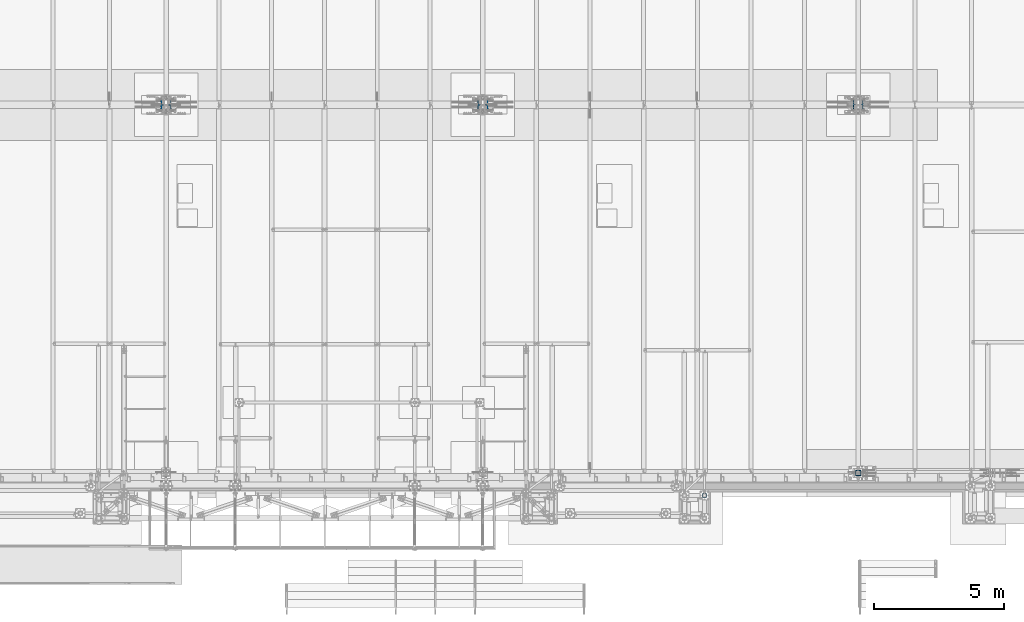
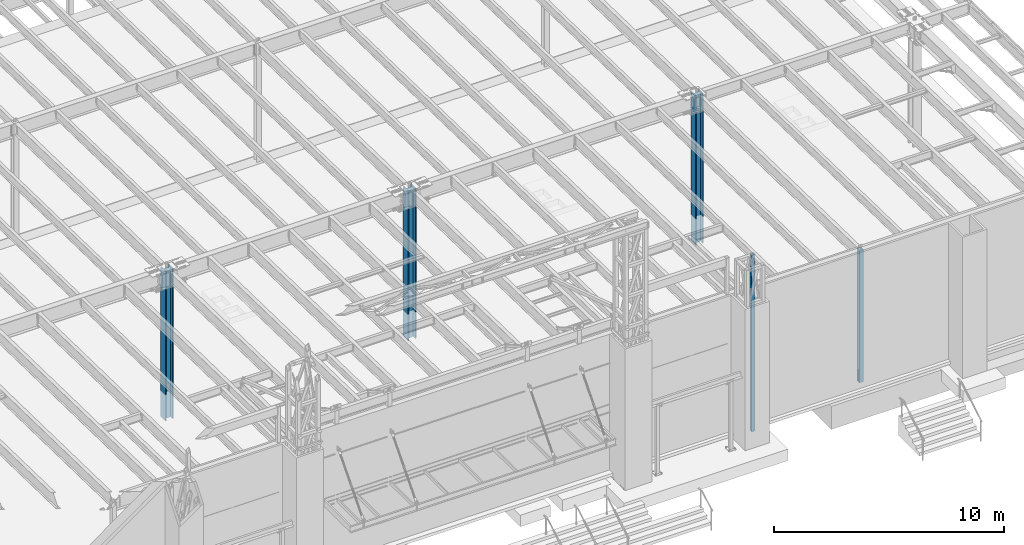
# One storey, part 897 of 1763: 5 columns, 5 elements without a shape of their own.
"""IFC2X3 building model written with IfcOpenShell, lengths in millimetres."""

from ifc_helpers import new_model, si_unit, frame, origin_with_axes, place, context, subcontext, project, spatial, faceted_brep, material, type_object, element, aggregate, save


model = new_model("IFC2X3")

# Units and contexts
model_context = context("Model", 3, precision=1e-05, world=origin_with_axes())
body_context = subcontext(model_context, "Body", "Model", "MODEL_VIEW")
ifc_project = project(units=[si_unit("LENGTHUNIT", "METRE", prefix="MILLI"), si_unit("AREAUNIT", "SQUARE_METRE"), si_unit("VOLUMEUNIT", "CUBIC_METRE"), si_unit("MASSUNIT", "GRAM", prefix="KILO"), si_unit("TIMEUNIT", "SECOND"), si_unit("PLANEANGLEUNIT", "RADIAN"), si_unit("SOLIDANGLEUNIT", "STERADIAN"), si_unit("THERMODYNAMICTEMPERATUREUNIT", "DEGREE_CELSIUS"), si_unit("LUMINOUSINTENSITYUNIT", "LUMEN")], contexts=[model_context])

# Site, building, storey
site_placement = place(None, origin_with_axes())
site = spatial("IfcSite", under=ifc_project, at=site_placement, CompositionType="ELEMENT")
building_placement = place(site_placement, origin_with_axes())
building = spatial("IfcBuilding", under=site, at=building_placement, Name="Undefined", CompositionType="ELEMENT")
storey_placement = place(building_placement, origin_with_axes())
storey = spatial("IfcBuildingStorey", under=building, at=storey_placement, Name="Undefined", CompositionType="ELEMENT", Elevation=0.0)

# Assembly, column
assembly_1_placement = place(storey_placement, origin_with_axes())
assembly_1 = element("IfcElementAssembly", 1, at=assembly_1_placement, inside=storey, Name="FRAME", AssemblyPlace="NOTDEFINED", PredefinedType="RIGID_FRAME")
ifc_material_1 = material()
column_type_1 = type_object("IfcColumnType", Name="HSS6X6X5/8", PredefinedType="NOTDEFINED")
column_1_placement = place(assembly_1_placement, frame((-40868.0383006056, -14579.5306029674, 5029.2), z_axis=(0.0, 1.0, 0.0), x_axis=(0.0, 0.0, 1.0)))
column_1 = element("IfcColumn", 2, at=column_1_placement, type_object=column_type_1, material=ifc_material_1, Name="COLUMN", ObjectType="HSS6X6X5/8", context=body_context, shape_type="Brep", body=[
    faceted_brep([(63.4999999999973, 60.3249999999971, -60.3250000000007), (63.4999999999973, -60.3249999999971, -60.3250000000007), (9429.74999873329, -60.3250000149637, -60.3250000000007), (9429.75000126672, 60.3249999850377, -60.3250000000007), (63.4999999999973, -60.3249999999971, 60.3250000000007), (9429.74999873329, -60.3250000149637, 60.3250000000007), (63.4999999999973, 60.3249999999971, 60.3250000000007), (9429.75000126672, 60.3249999850377, 60.3250000000007), (63.4999999999973, 76.1999999999971, -76.2000000000007), (63.4999999999973, 76.1999999999971, 76.2000000000007), (9429.75000000001, 76.1999999999971, 76.2000000000007), (9429.75000000001, 76.1999999999971, -76.2000000000007), (63.4999999999973, -76.1999999999971, 76.2000000000007), (9429.75000000001, -76.1999999999971, 76.2000000000007), (63.4999999999973, -76.1999999999971, -76.2000000000007), (9429.75000000001, -76.1999999999971, -76.2000000000007)], [[[0, 1, 2, 3]], [[1, 4, 5, 2]], [[4, 6, 7, 5]], [[6, 0, 3, 7]], [[8, 9, 10, 11]], [[9, 12, 13, 10]], [[12, 14, 15, 13]], [[14, 8, 11, 15]], [[13, 15, 11, 10], [5, 7, 3, 2]], [[14, 12, 9, 8], [6, 4, 1, 0]]]),
])
aggregate(assembly_1, [column_1])

assembly_2_placement = place(storey_placement, origin_with_axes())
assembly_2 = element("IfcElementAssembly", 3, at=assembly_2_placement, inside=storey, Name="COLUMN", AssemblyPlace="NOTDEFINED", PredefinedType="RIGID_FRAME")
column_type_2 = type_object("IfcColumnType", Name="HSS8X8X1/2", PredefinedType="NOTDEFINED")
column_2_placement = place(assembly_2_placement, frame((-34949.8372736984, -13716.0, 5029.2), z_axis=(0.0, 1.0, 0.0), x_axis=(0.0, 0.0, 1.0)))
column_2 = element("IfcColumn", 4, at=column_2_placement, type_object=column_type_2, material=ifc_material_1, Name="COLUMN", ObjectType="HSS8X8X1/2", context=body_context, shape_type="Brep", body=[
    faceted_brep([(7150.10000000001, 88.9000000000015, 6.35018100146408), (7137.40000000001, 101.599999999999, 6.35018100146408), (6491.28751239777, 101.599999999999, 6.35018100146408), (6491.28751239777, 88.9000000000015, 6.35018100146408), (6487.03494268262, 101.599999999999, 7.19606971095163), (6487.03494268262, 88.9000000000015, 7.19606971095163), (6483.42978815696, 101.599999999999, 9.60495695139434), (6483.42978815696, 88.9000000000015, 9.60495695139434), (6481.02090091652, 101.599999999999, 13.2101114770503), (6481.02090091652, 88.9000000000015, 13.2101114770503), (6480.17501220703, 101.599999999999, 17.4626811921989), (6480.17501220703, 88.9000000000015, 17.4626811921989), (6481.02090091652, 101.599999999999, 21.7152509073476), (6481.02090091652, 88.9000000000015, 21.7152509073476), (6483.42978815696, 101.599999999999, 25.3204054330035), (6483.42978815696, 88.9000000000015, 25.3204054330035), (6487.03494268262, 101.599999999999, 27.7292926734463), (6487.03494268262, 88.9000000000015, 27.7292926734463), (6491.28751239777, 101.599999999999, 28.5751813829338), (6491.28751239777, 88.9000000000015, 28.5751813829338), (7150.10000000001, 88.9000000000015, 28.5751813829338), (7137.40000000001, 101.599999999999, 28.5751813829338), (101.599999999999, 88.9000000000015, 14.2875007629391), (101.599999999999, 101.599999999999, 14.2875007629391), (763.464319038182, 101.599999999999, 14.2875007629391), (763.464319038182, 88.9000000000015, 14.2875007629391), (768.324398556228, 101.599999999999, 13.3207708403515), (768.324398556228, 88.9000000000015, 13.3207708403515), (772.444575024381, 101.599999999999, 10.567756939874), (772.444575024381, 88.9000000000015, 10.567756939874), (775.19758892486, 101.599999999999, 6.44758047172036), (775.19758892486, 88.9000000000015, 6.44758047172036), (776.164318847447, 101.599999999999, 1.58750095367395), (776.164318847447, 88.9000000000015, 1.58750095367395), (776.164318847447, 101.599999999999, -1.58750019073523), (776.164318847447, 88.9000000000015, -1.58750019073523), (775.19758892486, 101.599999999999, -6.44757970878163), (775.19758892486, 88.9000000000015, -6.44757970878163), (772.444575024381, 101.599999999999, -10.5677561769353), (772.444575024381, 88.9000000000015, -10.5677561769353), (768.324398556228, 101.599999999999, -13.3207700774128), (768.324398556228, 88.9000000000015, -13.3207700774128), (763.464319038182, 101.599999999999, -14.2875000000004), (763.464319038182, 88.9000000000015, -14.2875000000004), (101.599999999999, 101.599999999999, -14.2875000000004), (101.599999999999, 88.9000000000015, -14.2875000000004), (6588.91045414009, -15.8749990520446, 88.8999999999996), (6588.91045414009, -15.8749990520446, 101.6), (7137.40000000001, -15.8749990520446, 101.6), (7150.10000000001, -15.8749990520446, 88.8999999999996), (6586.48041438107, -15.3916340907526, 88.8999999999996), (6586.48041438107, -15.3916340907526, 101.6), (6584.42032614699, -14.015127140512, 88.8999999999996), (6584.42032614699, -14.015127140512, 101.6), (6583.04381919675, -11.9550389064316, 88.8999999999996), (6583.04381919675, -11.9550389064316, 101.6), (6582.56045423546, -9.52499914741202, 88.8999999999996), (6582.56045423546, -9.52499914741202, 101.6), (6583.04381919675, -7.09495938839245, 88.8999999999996), (6583.04381919675, -7.09495938839245, 101.6), (6584.42032614699, -5.03487115431199, 88.8999999999996), (6584.42032614699, -5.03487115431199, 101.6), (6586.48041438107, -3.6583642040714, 88.8999999999996), (6586.48041438107, -3.6583642040714, 101.6), (6588.91045414009, -3.17499924277945, 88.8999999999996), (6588.91045414009, -3.17499924277945, 101.6), (7150.10000000001, -3.17499924277945, 88.8999999999996), (7137.40000000001, -3.17499924277945, 101.6), (7137.40000000001, 101.599999999999, 101.6), (101.599999999999, 101.599999999999, 101.6), (101.599999999999, -101.599999999999, 101.6), (7137.40000000001, -101.599999999999, 101.6), (101.599999999999, 88.9000000000015, -88.8999999999996), (101.599999999999, -88.9000000000015, -88.8999999999996), (7150.10000000001, -88.9000000000015, -88.8999999999996), (7150.10000000001, 88.9000000000015, -88.8999999999996), (101.599999999999, -101.599999999999, -101.6), (101.599999999999, 101.599999999999, -101.6), (7137.40000000001, 101.599999999999, -101.6), (7137.40000000001, -101.599999999999, -101.6), (7150.10000000001, -88.9000000000015, 6.35018100146408), (7137.40000000001, -101.599999999999, 6.35018100146408), (6491.28750019074, -88.9000000000015, 6.35018100146408), (6491.28750019074, -101.599999999999, 6.35018100146408), (6487.03493047559, -88.9000000000015, 7.19606971095163), (6487.03493047559, -101.599999999999, 7.19606971095163), (6483.42977594993, -88.9000000000015, 9.60495695139434), (6483.42977594993, -101.599999999999, 9.60495695139434), (6481.02088870949, -88.9000000000015, 13.2101114770503), (6481.02088870949, -101.599999999999, 13.2101114770503), (6480.175, -88.9000000000015, 17.4626811921989), (6480.175, -101.599999999999, 17.4626811921989), (6481.02088870949, -88.9000000000015, 21.7152509073476), (6481.02088870949, -101.599999999999, 21.7152509073476), (6483.42977594993, -88.9000000000015, 25.3204054330035), (6483.42977594993, -101.599999999999, 25.3204054330035), (6487.03493047559, -88.9000000000015, 27.7292926734463), (6487.03493047559, -101.599999999999, 27.7292926734463), (101.599999999999, -101.599999999999, 14.2875007629391), (763.464319038182, -101.599999999999, 14.2875007629391), (768.324398556228, -101.599999999999, 13.3207708403515), (772.444575024381, -101.599999999999, 10.567756939874), (775.19758892486, -101.599999999999, 6.44758047172036), (776.164318847447, -101.599999999999, 1.58750095367395), (776.164318847447, -101.599999999999, -1.58750019073523), (775.19758892486, -101.599999999999, -6.44757970878163), (772.444575024381, -101.599999999999, -10.5677561769353), (768.324398556228, -101.599999999999, -13.3207700774128), (763.464319038182, -101.599999999999, -14.2875000000004), (101.599999999999, -101.599999999999, -14.2875000000004), (6491.28750019074, -101.599999999999, 28.5751813829338), (7137.40000000001, -101.599999999999, 28.5751813829338), (101.599999999999, -88.9000000000015, -14.2875000000004), (763.464319038182, -88.9000000000015, -14.2875000000004), (768.324398556228, -88.9000000000015, -13.3207700774128), (772.444575024381, -88.9000000000015, -10.5677561769353), (775.19758892486, -88.9000000000015, -6.44757970878163), (776.164318847447, -88.9000000000015, -1.58750019073523), (776.164318847447, -88.9000000000015, 1.58750095367395), (775.19758892486, -88.9000000000015, 6.44758047172036), (772.444575024381, -88.9000000000015, 10.567756939874), (768.324398556228, -88.9000000000015, 13.3207708403515), (763.464319038182, -88.9000000000015, 14.2875007629391), (101.599999999999, -88.9000000000015, 14.2875007629391), (101.599999999999, 88.9000000000015, 88.8999999999996), (101.599999999999, -88.9000000000015, 88.8999999999996), (7150.10000000001, -88.9000000000015, 88.8999999999996), (7150.10000000001, -88.9000000000015, 28.5751813829338), (6491.28750019074, -88.9000000000015, 28.5751813829338), (7150.10000000001, 88.9000000000015, 88.8999999999996)], [[[0, 1, 2, 3]], [[3, 2, 4, 5]], [[5, 4, 6, 7]], [[7, 6, 8, 9]], [[9, 8, 10, 11]], [[11, 10, 12, 13]], [[13, 12, 14, 15]], [[15, 14, 16, 17]], [[17, 16, 18, 19]], [[20, 19, 18, 21]], [[22, 23, 24, 25]], [[25, 24, 26, 27]], [[27, 26, 28, 29]], [[29, 28, 30, 31]], [[31, 30, 32, 33]], [[33, 32, 34, 35]], [[35, 34, 36, 37]], [[37, 36, 38, 39]], [[39, 38, 40, 41]], [[41, 40, 42, 43]], [[43, 42, 44, 45]], [[46, 47, 48, 49]], [[47, 46, 50, 51]], [[51, 50, 52, 53]], [[53, 52, 54, 55]], [[55, 54, 56, 57]], [[57, 56, 58, 59]], [[59, 58, 60, 61]], [[61, 60, 62, 63]], [[63, 62, 64, 65]], [[65, 64, 66, 67]], [[47, 51, 53, 55, 57, 59, 61, 63, 65, 67, 68, 69, 70, 71, 48]], [[72, 73, 74, 75]], [[76, 77, 78, 79]], [[74, 79, 78, 75]], [[79, 74, 80, 81]], [[80, 82, 83, 81]], [[83, 82, 84, 85]], [[85, 84, 86, 87]], [[87, 86, 88, 89]], [[89, 88, 90, 91]], [[91, 90, 92, 93]], [[93, 92, 94, 95]], [[95, 94, 96, 97]], [[71, 70, 98, 99, 100, 101, 102, 103, 104, 105, 106, 107, 108, 109, 76, 79, 81, 83, 85, 87, 89, 91, 93, 95, 97, 110, 111]], [[73, 72, 45, 44, 77, 76, 109, 112]], [[108, 113, 112, 109]], [[107, 114, 113, 108]], [[106, 115, 114, 107]], [[105, 116, 115, 106]], [[104, 117, 116, 105]], [[103, 118, 117, 104]], [[102, 119, 118, 103]], [[101, 120, 119, 102]], [[100, 121, 120, 101]], [[99, 122, 121, 100]], [[98, 123, 122, 99]], [[70, 69, 23, 22, 124, 125, 123, 98]], [[96, 94, 92, 90, 88, 86, 84, 82, 80, 74, 73, 112, 113, 114, 115, 116, 117, 118, 119, 120, 121, 122, 123, 125, 126, 127, 128]], [[97, 96, 128, 110]], [[127, 111, 110, 128]], [[126, 71, 111, 127]], [[49, 48, 71, 126]], [[125, 124, 129, 66, 64, 62, 60, 58, 56, 54, 52, 50, 46, 49, 126]], [[67, 66, 129, 68]], [[68, 129, 20, 21]], [[16, 14, 12, 10, 8, 6, 4, 2, 1, 78, 77, 44, 42, 40, 38, 36, 34, 32, 30, 28, 26, 24, 23, 69, 68, 21, 18]], [[75, 78, 1, 0]], [[129, 124, 22, 25, 27, 29, 31, 33, 35, 37, 39, 41, 43, 45, 72, 75, 0, 3, 5, 7, 9, 11, 13, 15, 17, 19, 20]]]),
])
aggregate(assembly_2, [column_2])

assembly_3_placement = place(storey_placement, origin_with_axes())
assembly_3 = element("IfcElementAssembly", 5, at=assembly_3_placement, inside=storey, Name="COLUMN", AssemblyPlace="NOTDEFINED", PredefinedType="RIGID_FRAME")
ifc_material_2 = material(Name="STEEL/A992")
column_type_3 = type_object("IfcColumnType", Name="W14X211", PredefinedType="NOTDEFINED")
column_3_placement = place(assembly_3_placement, frame((-34949.837273698, 457.199999999951, 3810.0), z_axis=(-1.0, 0.0, 0.0), x_axis=(0.0, 0.0, 1.0)))
column_3 = element("IfcColumn", 6, at=column_3_placement, type_object=column_type_3, material=ifc_material_2, Name="COLUMN", ObjectType="W14X211", context=body_context, shape_type="Brep", body=[
    faceted_brep([(124.513583392817, -200.025, 200.025000000001), (124.513583392817, 200.025, 200.025000000001), (101.600000000001, 200.025, 160.337500000001), (101.600000000001, 12.7, 160.337500000001), (101.600000000001, -12.7, 160.337500000001), (101.600000000001, -200.025, 160.337500000001), (8069.82117149519, 12.7, -160.337500000001), (8069.82117149519, 200.025, -160.337500000001), (101.600000000001, 200.025, -160.337500000001), (101.600000000001, 12.7, -160.337500000001), (8069.82117149519, -200.025, 160.337500000001), (8069.82117149519, -200.025, 200.025000000001), (8069.82117149519, -12.7, 160.337500000001), (8069.82117149519, 12.7, 160.337500000001), (8069.82117149519, 200.025, 160.337500000001), (8069.82117149519, 200.025, 200.025000000001), (8069.82117149519, -12.7, -160.337500000001), (8069.82117149519, -200.025, -160.337500000001), (8069.82117149519, -200.025, -200.025000000001), (8069.82117149519, 200.025, -200.025000000001), (101.600000000001, -12.7, -160.337500000001), (101.600000000001, -200.025, -160.337500000001), (124.513591400617, -200.025, -200.025000000001), (124.513591400617, 200.025, -200.025000000001), (101.600000000001, -12.7, -159.940498626711), (101.600000000001, 12.7, -159.940498626711), (152.400000000001, -12.7, -159.940498626711), (152.400000000001, 12.7000000000032, -159.940498626711), (152.400000000001, -12.7, -136.525499618532), (152.400000000001, 12.7000000000032, -136.525499618532), (151.674952576209, -12.7, -132.88044007124), (151.674952576209, 12.7000000000032, -132.88044007124), (149.610192202533, -12.7, -129.79030779747), (149.610192202533, 12.7000000000032, -129.79030779747), (146.520059928766, -12.7, -127.725547423797), (146.520059928766, 12.7000000000032, -127.725547423797), (142.875000381471, -12.7, -127.000500000002), (142.875000381471, 12.7000000000032, -127.000500000002), (101.600000000001, -12.7, -127.000000000015), (126.999999618533, 12.7000000000071, -127.000000000015), (101.600000000001, -12.7, 126.999999999985), (126.999999618533, 12.7000000000071, 126.999999999985), (142.87500190735, -12.7, 127.000500000002), (142.87500190735, 12.7000000000032, 127.000500000002), (146.520061454645, -12.7, 127.725547423797), (146.520061454645, 12.7000000000032, 127.725547423797), (149.610193728412, -12.7, 129.79030779747), (149.610193728412, 12.7000000000032, 129.79030779747), (151.674954102088, -12.7, 132.88044007124), (151.674954102088, 12.7000000000032, 132.88044007124), (152.40000152588, -12.7, 136.525499618532), (152.40000152588, 12.7000000000032, 136.525499618532), (152.40000152588, -12.7, 159.940498626711), (152.40000152588, 12.7000000000032, 159.940498626711), (101.600000000001, -12.7, 159.940498626711), (101.600000000001, 12.7, 159.940498626711)], [[[0, 1, 2, 3, 4, 5]], [[6, 7, 8, 9]], [[10, 11, 0, 5]], [[12, 10, 5, 4]], [[6, 13, 14, 15, 11, 10, 12, 16, 17, 18, 19, 7]], [[17, 16, 20, 21]], [[18, 17, 21, 22]], [[19, 18, 22, 23]], [[7, 19, 23, 8]], [[22, 21, 20, 9, 8, 23]], [[9, 20, 24, 25]], [[26, 27, 25, 24]], [[28, 29, 27, 26]], [[30, 31, 29, 28]], [[32, 33, 31, 30]], [[34, 35, 33, 32]], [[36, 37, 35, 34]], [[38, 39, 37, 36]], [[39, 38, 40, 41]], [[42, 43, 41, 40]], [[44, 45, 43, 42]], [[46, 47, 45, 44]], [[48, 49, 47, 46]], [[50, 51, 49, 48]], [[52, 53, 51, 50]], [[48, 46, 44, 42, 40, 38, 36, 34, 32, 30, 28, 26, 24, 20, 16, 12, 4, 54, 52, 50]], [[55, 54, 4, 3]], [[53, 52, 54, 55]], [[3, 13, 6, 9, 25, 27, 29, 31, 33, 35, 37, 39, 41, 43, 45, 47, 49, 51, 53, 55]], [[14, 13, 3, 2]], [[15, 14, 2, 1]], [[11, 15, 1, 0]]]),
])
aggregate(assembly_3, [column_3])

assembly_4_placement = place(storey_placement, origin_with_axes())
assembly_4 = element("IfcElementAssembly", 7, at=assembly_4_placement, inside=storey, Name="COLUMN", AssemblyPlace="NOTDEFINED", PredefinedType="RIGID_FRAME")
column_type_4 = type_object("IfcColumnType", Name="W14X283", PredefinedType="NOTDEFINED")
column_4_placement = place(assembly_4_placement, frame((-49402.4372736986, 457.200000000003, 3810.0), z_axis=(-1.0, 0.0, 0.0), x_axis=(0.0, 0.0, 1.0)))
column_4 = element("IfcColumn", 8, at=column_4_placement, type_object=column_type_4, material=ifc_material_2, Name="COLUMN", ObjectType="W14X283", context=body_context, shape_type="Brep", body=[
    faceted_brep([(134.937501525871, 16.6687519073421, 127.000500000002), (134.937501525871, 16.66875, -127.000500000002), (101.599999999999, -16.66875, -127.000500000002), (101.599999999999, -16.66875, 127.000500000002), (8079.3461712618, 204.7875, -212.724999999999), (8079.3461712618, -204.7875, -212.724999999999), (131.845597074295, -204.7875, -212.724999999999), (131.845597074295, 204.7875, -212.724999999999), (8079.3461712618, -204.7875, -160.337500000001), (101.599999999999, -204.7875, -160.337500000001), (8079.3461712618, -16.66875, -160.337500000001), (101.599999999999, -16.66875, -160.337500000001), (142.875000381469, -16.66875, -127.000500000002), (142.875000381469, 16.66875, -127.000500000002), (146.520059928765, 16.66875, -127.725547423797), (146.520059928765, -16.66875, -127.725547423797), (149.610192202531, 16.66875, -129.79030779747), (149.610192202531, -16.66875, -129.79030779747), (151.674952576207, 16.66875, -132.88044007124), (151.674952576207, -16.66875, -132.88044007124), (152.4, 16.66875, -136.525499618532), (152.4, -16.66875, -136.525499618532), (152.4, 16.66875, -159.940498626711), (152.4, -16.66875, -159.940498626711), (101.599999999999, 16.66875, -159.940498626711), (101.599999999999, -16.66875, -159.940498626711), (101.599999999999, 16.66875, -160.337500000001), (8079.3461712618, 16.66875, -160.337500000001), (8079.3461712618, 204.7875, -160.337500000001), (101.599999999999, 204.7875, -160.337500000001), (8079.3461712618, 16.66875, 160.337500000001), (8079.3461712618, 204.7875, 160.337500000001), (8079.3461712618, 204.7875, 212.724999999999), (8079.3461712618, -204.7875, 212.724999999999), (8079.3461712618, -204.7875, 160.337500000001), (8079.3461712618, -16.66875, 160.337500000001), (101.599999999999, 16.66875, 160.337500000001), (101.599999999999, 204.7875, 160.337500000001), (131.845590950688, 204.7875, 212.724999999999), (131.845590950688, -204.7875, 212.724999999999), (101.599999999999, -204.7875, 160.337500000001), (101.599999999999, -16.66875, 160.337500000001), (101.599999999999, 16.66875, 159.940498626711), (101.599999999999, -16.66875, 159.940498626711), (152.400001525878, 16.66875, 159.940498626711), (152.400001525878, -16.66875, 159.940498626711), (152.400001525878, 16.66875, 136.525499618532), (152.400001525878, -16.66875, 136.525499618532), (151.674954102086, 16.66875, 132.88044007124), (151.674954102086, -16.66875, 132.88044007124), (149.61019372841, 16.66875, 129.79030779747), (149.61019372841, -16.66875, 129.79030779747), (146.520061454643, 16.66875, 127.725547423797), (146.520061454643, -16.66875, 127.725547423797), (142.875001907348, 16.66875, 127.000500000002), (142.875001907348, -16.66875, 127.000500000002)], [[[0, 1, 2, 3]], [[4, 5, 6, 7]], [[5, 8, 9, 6]], [[8, 10, 11, 9]], [[12, 13, 14, 15]], [[15, 14, 16, 17]], [[17, 16, 18, 19]], [[19, 18, 20, 21]], [[21, 20, 22, 23]], [[23, 22, 24, 25]], [[26, 11, 25, 24]], [[27, 28, 29, 26]], [[6, 9, 11, 26, 29, 7]], [[28, 4, 7, 29]], [[27, 30, 31, 32, 33, 34, 35, 10, 8, 5, 4, 28]], [[31, 30, 36, 37]], [[32, 31, 37, 38]], [[33, 32, 38, 39]], [[34, 33, 39, 40]], [[35, 34, 40, 41]], [[39, 38, 37, 36, 41, 40]], [[42, 43, 41, 36]], [[44, 45, 43, 42]], [[45, 44, 46, 47]], [[47, 46, 48, 49]], [[49, 48, 50, 51]], [[51, 50, 52, 53]], [[53, 52, 54, 55]], [[55, 54, 0, 3]], [[12, 15, 17, 19, 21, 23, 25, 11, 10, 35, 41, 43, 45, 47, 49, 51, 53, 55, 3, 2]], [[13, 12, 2, 1]], [[54, 52, 50, 48, 46, 44, 42, 36, 30, 27, 26, 24, 22, 20, 18, 16, 14, 13, 1, 0]]]),
])
aggregate(assembly_4, [column_4])

assembly_5_placement = place(storey_placement, origin_with_axes())
assembly_5 = element("IfcElementAssembly", 9, at=assembly_5_placement, inside=storey, Name="COLUMN", AssemblyPlace="NOTDEFINED", PredefinedType="RIGID_FRAME")
column_5_placement = place(assembly_5_placement, frame((-61594.4372736986, 457.200000000006, 3810.0), z_axis=(-1.0, 0.0, 0.0), x_axis=(0.0, 0.0, 1.0)))
column_5 = element("IfcColumn", 10, at=column_5_placement, type_object=column_type_4, material=ifc_material_2, Name="COLUMN", ObjectType="W14X283", context=body_context, shape_type="Brep", body=[
    faceted_brep([(131.845590950688, -204.7875, 212.724999999999), (131.845590950688, 204.7875, 212.724999999999), (101.599999999999, 204.7875, 160.337500000001), (101.599999999999, 16.66875, 160.337500000001), (101.599999999999, -16.66875, 160.337500000001), (101.599999999999, -204.7875, 160.337500000001), (8079.3461712618, 16.66875, -160.337500000001), (8079.3461712618, 204.7875, -160.337500000001), (101.599999999999, 204.7875, -160.337500000001), (101.599999999999, 16.66875, -160.337500000001), (8079.3461712618, -204.7875, 160.337500000001), (8079.3461712618, -204.7875, 212.724999999999), (8079.3461712618, -16.66875, 160.337500000001), (8079.3461712618, 16.66875, 160.337500000001), (8079.3461712618, 204.7875, 160.337500000001), (8079.3461712618, 204.7875, 212.724999999999), (8079.3461712618, -16.66875, -160.337500000001), (8079.3461712618, -204.7875, -160.337500000001), (8079.3461712618, -204.7875, -212.724999999999), (8079.3461712618, 204.7875, -212.724999999999), (101.599999999999, -16.66875, -160.337500000001), (101.599999999999, -204.7875, -160.337500000001), (131.845597074295, -204.7875, -212.724999999999), (131.845597074295, 204.7875, -212.724999999999), (101.599999999999, -16.66875, -159.940498626711), (101.599999999999, 16.66875, -159.940498626711), (152.4, -16.66875, -159.940498626711), (152.4, 16.66875, -159.940498626711), (152.4, -16.66875, -136.525499618532), (152.4, 16.66875, -136.525499618532), (151.674952576207, -16.66875, -132.88044007124), (151.674952576207, 16.66875, -132.88044007124), (149.610192202531, -16.66875, -129.79030779747), (149.610192202531, 16.66875, -129.79030779747), (146.520059928765, -16.66875, -127.725547423797), (146.520059928765, 16.66875, -127.725547423797), (142.875000381469, -16.66875, -127.000500000002), (142.875000381469, 16.66875, -127.000500000002), (101.599999999999, -16.66875, -127.000500000002), (134.937501525871, 16.66875, -127.000500000002), (134.937501525871, 16.6687519073421, 127.000500000002), (101.599999999999, -16.66875, 127.000500000002), (142.875001907348, -16.66875, 127.000500000002), (142.875001907348, 16.66875, 127.000500000002), (146.520061454643, -16.66875, 127.725547423797), (146.520061454643, 16.66875, 127.725547423797), (149.61019372841, -16.66875, 129.79030779747), (149.61019372841, 16.66875, 129.79030779747), (151.674954102086, -16.66875, 132.88044007124), (151.674954102086, 16.66875, 132.88044007124), (152.400001525878, -16.66875, 136.525499618532), (152.400001525878, 16.66875, 136.525499618532), (152.400001525878, -16.66875, 159.940498626711), (152.400001525878, 16.66875, 159.940498626711), (101.599999999999, -16.66875, 159.940498626711), (101.599999999999, 16.66875, 159.940498626711)], [[[0, 1, 2, 3, 4, 5]], [[6, 7, 8, 9]], [[10, 11, 0, 5]], [[12, 10, 5, 4]], [[6, 13, 14, 15, 11, 10, 12, 16, 17, 18, 19, 7]], [[17, 16, 20, 21]], [[18, 17, 21, 22]], [[19, 18, 22, 23]], [[7, 19, 23, 8]], [[22, 21, 20, 9, 8, 23]], [[9, 20, 24, 25]], [[26, 27, 25, 24]], [[28, 29, 27, 26]], [[30, 31, 29, 28]], [[32, 33, 31, 30]], [[34, 35, 33, 32]], [[36, 37, 35, 34]], [[37, 36, 38, 39]], [[40, 39, 38, 41]], [[42, 43, 40, 41]], [[44, 45, 43, 42]], [[46, 47, 45, 44]], [[48, 49, 47, 46]], [[50, 51, 49, 48]], [[52, 53, 51, 50]], [[36, 34, 32, 30, 28, 26, 24, 20, 16, 12, 4, 54, 52, 50, 48, 46, 44, 42, 41, 38]], [[55, 54, 4, 3]], [[53, 52, 54, 55]], [[43, 45, 47, 49, 51, 53, 55, 3, 13, 6, 9, 25, 27, 29, 31, 33, 35, 37, 39, 40]], [[14, 13, 3, 2]], [[15, 14, 2, 1]], [[11, 15, 1, 0]]]),
])
aggregate(assembly_5, [column_5])

save(model, "model.ifc")
